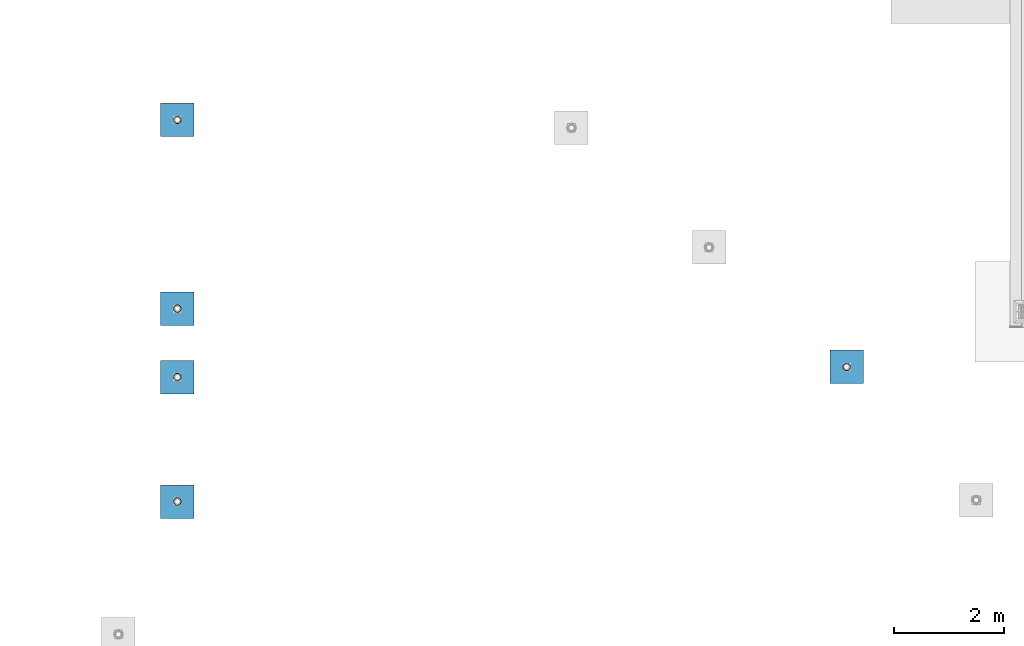
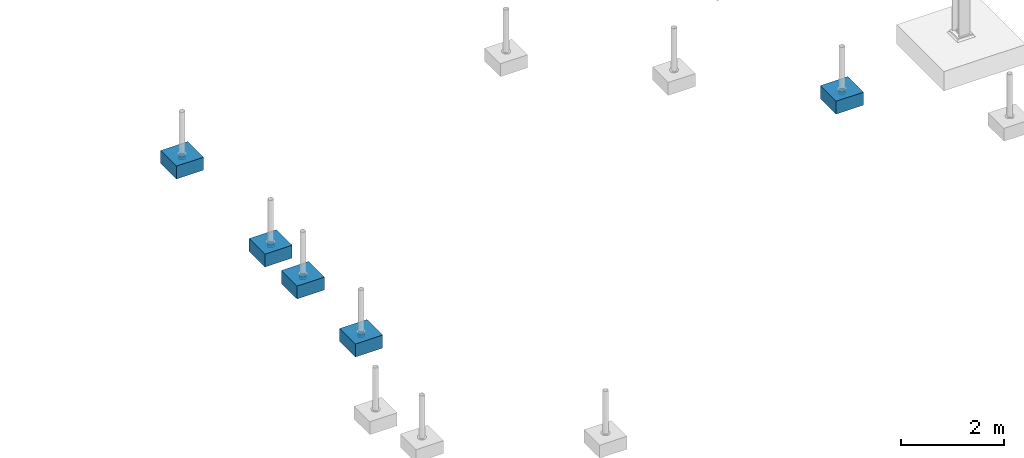
# One storey, part 1534 of 3843: 10 columns, 10 elements without a shape of their own.
"""IFC2X3 building model written with IfcOpenShell, lengths in millimetres."""

import ifcopenshell
import ifcopenshell.guid

model = None  # the IFC model being written
_history = None  # IfcOwnerHistory: only IFC2X3 demands one
_inside = {}  # id of a spatial element -> (the spatial element, [elements in it])
_under = {}  # id of a project, library or spatial element -> (it, [spatial elements below it])
_declared = {}  # id of a project -> (the project, [libraries it declares])
_typed = {}  # id of a type object -> (the type object, [elements of that type])
_made_of = {}  # id of a material, layer set ... -> (it, [elements and type objects made of it])


def new_model(schema):
    """Start an empty IFC model of exactly this schema.

    Asked for "IFC4X3", IfcOpenShell would pick the latest addendum, in which some entities
    have other attributes; the version numbers below select the first issue.
    IFC2X3 requires an IfcOwnerHistory on every rooted entity: one is made here for all.
    """
    global model, _history
    if schema == "IFC4X3":
        model = ifcopenshell.file(schema_version=(4, 3, 0, 0))
    else:
        model = ifcopenshell.file(schema=schema)
    _inside.clear()
    _under.clear()
    _declared.clear()
    _typed.clear()
    _made_of.clear()
    _history = None
    if model.schema == "IFC2X3":
        org = make("IfcOrganization", Name="unknown")
        user = make(
            "IfcPersonAndOrganization",
            ThePerson=make("IfcPerson", FamilyName="unknown"),
            TheOrganization=org,
        )
        app = make(
            "IfcApplication",
            ApplicationDeveloper=org,
            Version="unknown",
            ApplicationFullName="unknown",
            ApplicationIdentifier="unknown",
        )
        _history = make(
            "IfcOwnerHistory",
            OwningUser=user,
            OwningApplication=app,
            ChangeAction="ADDED",
            CreationDate=0,
        )
    return model


def make(cls, **values):
    """One entity of the class cls with the attributes given. An attribute that is None is left unset."""
    return model.create_entity(
        cls, **{name: value for name, value in values.items() if value is not None}
    )


def rooted(cls, **values):
    """An entity with a GlobalId (a new one), such as an element, a storey or a relation."""
    return make(cls, GlobalId=ifcopenshell.guid.new(), OwnerHistory=_history, **values)


def si_unit(unit_type, name, prefix=None):
    """IfcSIUnit, for example si_unit("LENGTHUNIT", "METRE", prefix="MILLI")."""
    return make("IfcSIUnit", UnitType=unit_type, Prefix=prefix, Name=name)


def assignment(units):
    """IfcUnitAssignment: the units of a project."""
    return None if units is None else make("IfcUnitAssignment", Units=units)


def point(xyz):
    """IfcCartesianPoint."""
    return None if xyz is None else make("IfcCartesianPoint", Coordinates=xyz)


def direction(xyz):
    """IfcDirection."""
    return None if xyz is None else make("IfcDirection", DirectionRatios=xyz)


def frame(location, z_axis=None, x_axis=None):
    """IfcAxis2Placement3D, a coordinate frame: its origin and axes. An axis left out is left unset."""
    return make(
        "IfcAxis2Placement3D",
        Location=point(location),
        Axis=direction(z_axis),
        RefDirection=direction(x_axis),
    )


def origin_with_axes():
    """The frame at (0, 0, 0) with the z axis (0, 0, 1) and the x axis (1, 0, 0) written out."""
    return frame((0.0, 0.0, 0.0), z_axis=(0.0, 0.0, 1.0), x_axis=(1.0, 0.0, 0.0))


def place(relative_to, where):
    """IfcLocalPlacement: puts the frame where relative to a parent placement (None: the world)."""
    return make(
        "IfcLocalPlacement", PlacementRelTo=relative_to, RelativePlacement=where
    )


def context(
    kind, dimensions, precision=None, world=None, true_north=None, identifier=None
):
    """IfcGeometricRepresentationContext, for example the 3D "Model" context."""
    return make(
        "IfcGeometricRepresentationContext",
        ContextIdentifier=identifier,
        ContextType=kind,
        CoordinateSpaceDimension=dimensions,
        Precision=precision,
        WorldCoordinateSystem=world,
        TrueNorth=true_north,
    )


def subcontext(parent, identifier, kind, view, scale=None):
    """IfcGeometricRepresentationSubContext, for example "Body" below "Model"."""
    return make(
        "IfcGeometricRepresentationSubContext",
        ContextIdentifier=identifier,
        ContextType=kind,
        ParentContext=parent,
        TargetScale=scale,
        TargetView=view,
    )


def project(units=None, contexts=None):
    """IfcProject with its units and contexts."""
    return rooted(
        "IfcProject",
        Name="project",
        RepresentationContexts=contexts,
        UnitsInContext=assignment(units),
    )


def spatial(cls, under=None, at=None, **own):
    """A site, building, storey or space (cls), placed at a placement, below another one or the project."""
    s = rooted(cls, ObjectPlacement=at, **own)
    if under is not None:
        _under.setdefault(under.id(), (under, []))[1].append(s)
    return s


def faces_of(points, faces, orient=None, outer=None):
    """IfcFace entities. A face is a list of loops; a loop is a list of indices into points, from 0.

    orient and outer hold one flag for each loop. By default every Orientation is true, the
    first loop of a face is its IfcFaceOuterBound and the others are IfcFaceBound.
    """
    made = []
    for i, loops in enumerate(faces):
        bounds = []
        for j, loop in enumerate(loops):
            is_outer = j == 0 if outer is None else outer[i][j]
            bounds.append(
                make(
                    "IfcFaceOuterBound" if is_outer else "IfcFaceBound",
                    Bound=make("IfcPolyLoop", Polygon=[points[k] for k in loop]),
                    Orientation=True if orient is None else orient[i][j],
                )
            )
        made.append(make("IfcFace", Bounds=bounds))
    return made


def faceted_brep(points, faces, orient=None, outer=None, voids=None):
    """IfcFacetedBrep: a solid bounded by flat faces; with voids (closed shells), ...WithVoids."""
    shared = [point(p) for p in points]
    hull = make("IfcClosedShell", CfsFaces=faces_of(shared, faces, orient, outer))
    if voids is None:
        return make("IfcFacetedBrep", Outer=hull)
    return make(
        "IfcFacetedBrepWithVoids",
        Outer=hull,
        Voids=[
            make(cls, CfsFaces=faces_of(shared, fs, o, b)) for cls, fs, o, b in voids
        ],
    )


def shape(context_of_items, identifier, shape_type, items):
    """IfcShapeRepresentation: the items that make up one representation, for example the "Body"."""
    return make(
        "IfcShapeRepresentation",
        ContextOfItems=context_of_items,
        RepresentationIdentifier=identifier,
        RepresentationType=shape_type,
        Items=items,
    )


def material(Name=None, Category=None):
    """IfcMaterial."""
    return make("IfcMaterial", Name=Name, Category=Category)


def made_of(thing, what):
    """Note that an element or type object is made of a material, layer set ...; save() writes the relation."""
    if what is not None:
        _made_of.setdefault(what.id(), (what, []))[1].append(thing)
    return thing


def type_object(cls, material=None, **own):
    """A type object (cls), such as IfcWallType, which elements share."""
    return made_of(rooted(cls, **own), material)


def element(
    cls,
    number,
    at=None,
    inside=None,
    cuts=None,
    type_object=None,
    material=None,
    context=None,
    identifier="Body",
    shape_type=None,
    held_by="IfcProductDefinitionShape",
    body=None,
    shapes=None,
    **own,
):
    """One element of the class cls, such as IfcWall. Its Tag is "e" and its number.

    at: its placement. inside: the storey or other place that contains it. cuts: it is an
    opening in that element (IfcRelVoidsElement). A single representation is given by context,
    identifier, shape_type and body (its items); several are given by shapes. held_by: the class
    of the entity that holds the representations. save() writes the other relations.
    """
    e = rooted(cls, Tag="e%d" % number, ObjectPlacement=at, **own)
    if body is not None:
        shapes = [shape(context, identifier, shape_type, body)]
    if shapes is not None:
        e.Representation = make(held_by, Representations=shapes)
    if inside is not None:
        _inside.setdefault(inside.id(), (inside, []))[1].append(e)
    if cuts is not None:
        rooted(
            "IfcRelVoidsElement", RelatingBuildingElement=cuts, RelatedOpeningElement=e
        )
    if type_object is not None:
        _typed.setdefault(type_object.id(), (type_object, []))[1].append(e)
    return made_of(e, material)


def aggregate(whole, parts):
    """IfcRelAggregates: a whole, such as a stair, and the parts it consists of."""
    return rooted("IfcRelAggregates", RelatingObject=whole, RelatedObjects=parts)


def save(model, path):
    """Write the relations noted so far, then the file.

    IfcRelAggregates (storeys below a building ...), IfcRelContainedInSpatialStructure (elements
    in a storey), IfcRelDefinesByType, IfcRelAssociatesMaterial and IfcRelDeclares: one each for
    every whole, place, type object, material and project.
    """
    for whole, parts in _under.values():
        aggregate(whole, parts)
    for where, things in _inside.values():
        rooted(
            "IfcRelContainedInSpatialStructure",
            RelatedElements=things,
            RelatingStructure=where,
        )
    for kind, things in _typed.values():
        rooted("IfcRelDefinesByType", RelatedObjects=things, RelatingType=kind)
    for what, things in _made_of.values():
        rooted("IfcRelAssociatesMaterial", RelatedObjects=things, RelatingMaterial=what)
    for by, libraries in _declared.values():
        rooted("IfcRelDeclares", RelatingContext=by, RelatedDefinitions=libraries)
    model.write(path)


model = new_model("IFC2X3")

# Units and contexts
model_context = context("Model", 3, precision=1e-05, world=origin_with_axes())
body_context = subcontext(model_context, "Body", "Model", "MODEL_VIEW")
ifc_project = project(units=[si_unit("LENGTHUNIT", "METRE", prefix="MILLI"), si_unit("AREAUNIT", "SQUARE_METRE"), si_unit("VOLUMEUNIT", "CUBIC_METRE"), si_unit("MASSUNIT", "GRAM", prefix="KILO"), si_unit("TIMEUNIT", "SECOND"), si_unit("PLANEANGLEUNIT", "RADIAN"), si_unit("SOLIDANGLEUNIT", "STERADIAN"), si_unit("THERMODYNAMICTEMPERATUREUNIT", "DEGREE_CELSIUS"), si_unit("LUMINOUSINTENSITYUNIT", "LUMEN")], contexts=[model_context])

# Site, building, storey
site_placement = place(None, origin_with_axes())
site = spatial("IfcSite", under=ifc_project, at=site_placement, CompositionType="ELEMENT")
building_placement = place(site_placement, origin_with_axes())
building = spatial("IfcBuilding", under=site, at=building_placement, Name="Undefined", CompositionType="ELEMENT")
storey_placement = place(building_placement, origin_with_axes())
storey = spatial("IfcBuildingStorey", under=building, at=storey_placement, Name="Undefined", CompositionType="ELEMENT", Elevation=0.0)

# Assembly, column
assembly_1_placement = place(storey_placement, origin_with_axes())
assembly_1 = element("IfcElementAssembly", 1, at=assembly_1_placement, inside=storey, Name="PLATE", AssemblyPlace="NOTDEFINED", PredefinedType="RIGID_FRAME")
ifc_material_1 = material()
column_type_1 = type_object("IfcColumnType", Name="PIPE5SCH40", PredefinedType="NOTDEFINED")
column_1_placement = place(assembly_1_placement, frame((-3243.064063, 88116.171877, 30378.4), z_axis=(-1.0, 0.0, 0.0), x_axis=(0.0, 0.0, 1.0)))
column_1 = element("IfcColumn", 2, at=column_1_placement, type_object=column_type_1, material=ifc_material_1, Name="PIPE_SLEEVE", ObjectType="PIPE5SCH40", context=body_context, shape_type="Brep", body=[
    faceted_brep([(0.0, -64.0587999999998, 0.0), (0.0, -60.9235391660477, 19.7952578392724), (76.2000000000007, -60.9235391660477, 19.7952578392724), (76.2000000000007, -64.0587999999998, 0.0), (0.0, -51.8246578392655, 37.6528179195593), (76.2000000000007, -51.8246578392655, 37.6528179195593), (0.0, -37.6528179195529, 51.8246578392718), (76.2000000000007, -37.6528179195529, 51.8246578392718), (0.0, -19.795257839266, 60.9235391660477), (76.2000000000007, -19.795257839266, 60.9235391660477), (0.0, 0.0, 64.0587999999989), (76.2000000000007, 0.0, 64.0587999999989), (0.0, 19.795257839266, 60.9235391660477), (76.2000000000007, 19.795257839266, 60.9235391660477), (0.0, 37.6528179195529, 51.8246578392718), (76.2000000000007, 37.6528179195529, 51.8246578392718), (0.0, 51.8246578392655, 37.6528179195593), (76.2000000000007, 51.8246578392655, 37.6528179195593), (0.0, 60.9235391660477, 19.7952578392724), (76.2000000000007, 60.9235391660477, 19.7952578392724), (0.0, 64.0587999999998, 0.0), (76.2000000000007, 64.0587999999998, 0.0), (0.0, 60.9235391660477, -19.7952578392724), (76.2000000000007, 60.9235391660477, -19.7952578392724), (0.0, 51.8246578392655, -37.6528179195593), (76.2000000000007, 51.8246578392655, -37.6528179195593), (0.0, 37.6528179195529, -51.8246578392718), (76.2000000000007, 37.6528179195529, -51.8246578392718), (0.0, 19.795257839266, -60.9235391660477), (76.2000000000007, 19.795257839266, -60.9235391660477), (0.0, 0.0, -64.0587999999989), (76.2000000000007, 0.0, -64.0587999999989), (0.0, -19.795257839266, -60.9235391660477), (76.2000000000007, -19.795257839266, -60.9235391660477), (0.0, -37.6528179195529, -51.8246578392718), (76.2000000000007, -37.6528179195529, -51.8246578392718), (0.0, -51.8246578392655, -37.6528179195593), (76.2000000000007, -51.8246578392655, -37.6528179195593), (0.0, -60.9235391660477, -19.7952578392724), (76.2000000000007, -60.9235391660477, -19.7952578392724), (0.0, -70.6120000000001, 0.0), (0.0, -67.1560027286332, -21.8203080068051), (76.2000000000007, -67.1560027286332, -21.8203080068051), (76.2000000000007, -70.6120000000001, 0.0), (0.0, -57.1263080068038, -41.5046922348702), (76.2000000000007, -57.1263080068038, -41.5046922348702), (0.0, -41.5046922348765, -57.126308006802), (76.2000000000007, -41.5046922348765, -57.126308006802), (0.0, -21.8203080068042, -67.1560027286323), (76.2000000000007, -21.8203080068042, -67.1560027286323), (0.0, 0.0, -70.6119999999937), (76.2000000000007, 0.0, -70.6119999999937), (0.0, 21.8203080068042, -67.1560027286323), (76.2000000000007, 21.8203080068042, -67.1560027286323), (0.0, 41.5046922348765, -57.126308006802), (76.2000000000007, 41.5046922348765, -57.126308006802), (0.0, 57.1263080068038, -41.5046922348702), (76.2000000000007, 57.1263080068038, -41.5046922348702), (0.0, 67.1560027286332, -21.8203080068051), (76.2000000000007, 67.1560027286332, -21.8203080068051), (0.0, 70.6120000000001, 0.0), (76.2000000000007, 70.6120000000001, 0.0), (0.0, 67.1560027286332, 21.8203080068051), (76.2000000000007, 67.1560027286332, 21.8203080068051), (0.0, 57.1263080068038, 41.5046922348702), (76.2000000000007, 57.1263080068038, 41.5046922348702), (0.0, 41.5046922348765, 57.126308006802), (76.2000000000007, 41.5046922348765, 57.126308006802), (0.0, 21.8203080068042, 67.1560027286323), (76.2000000000007, 21.8203080068042, 67.1560027286323), (0.0, 0.0, 70.6119999999937), (76.2000000000007, 0.0, 70.6119999999937), (0.0, -21.8203080068042, 67.1560027286323), (76.2000000000007, -21.8203080068042, 67.1560027286323), (0.0, -41.5046922348765, 57.126308006802), (76.2000000000007, -41.5046922348765, 57.126308006802), (0.0, -57.1263080068038, 41.5046922348702), (76.2000000000007, -57.1263080068038, 41.5046922348702), (0.0, -67.1560027286332, 21.8203080068051), (76.2000000000007, -67.1560027286332, 21.8203080068051)], [[[0, 1, 2, 3]], [[1, 4, 5, 2]], [[4, 6, 7, 5]], [[6, 8, 9, 7]], [[8, 10, 11, 9]], [[10, 12, 13, 11]], [[12, 14, 15, 13]], [[14, 16, 17, 15]], [[16, 18, 19, 17]], [[18, 20, 21, 19]], [[20, 22, 23, 21]], [[22, 24, 25, 23]], [[24, 26, 27, 25]], [[26, 28, 29, 27]], [[28, 30, 31, 29]], [[30, 32, 33, 31]], [[32, 34, 35, 33]], [[34, 36, 37, 35]], [[36, 38, 39, 37]], [[38, 0, 3, 39]], [[40, 41, 42, 43]], [[41, 44, 45, 42]], [[44, 46, 47, 45]], [[46, 48, 49, 47]], [[48, 50, 51, 49]], [[50, 52, 53, 51]], [[52, 54, 55, 53]], [[54, 56, 57, 55]], [[56, 58, 59, 57]], [[58, 60, 61, 59]], [[60, 62, 63, 61]], [[62, 64, 65, 63]], [[64, 66, 67, 65]], [[66, 68, 69, 67]], [[68, 70, 71, 69]], [[70, 72, 73, 71]], [[72, 74, 75, 73]], [[74, 76, 77, 75]], [[76, 78, 79, 77]], [[78, 40, 43, 79]], [[45, 47, 49, 51, 53, 55, 57, 59, 61, 63, 65, 67, 69, 71, 73, 75, 77, 79, 43, 42], [5, 7, 9, 11, 13, 15, 17, 19, 21, 23, 25, 27, 29, 31, 33, 35, 37, 39, 3, 2]], [[78, 76, 74, 72, 70, 68, 66, 64, 62, 60, 58, 56, 54, 52, 50, 48, 46, 44, 41, 40], [38, 36, 34, 32, 30, 28, 26, 24, 22, 20, 18, 16, 14, 12, 10, 8, 6, 4, 1, 0]]]),
])
aggregate(assembly_1, [column_1])

assembly_2_placement = place(storey_placement, origin_with_axes())
assembly_2 = element("IfcElementAssembly", 3, at=assembly_2_placement, inside=storey, Name="PLATE", AssemblyPlace="NOTDEFINED", PredefinedType="RIGID_FRAME")
column_2_placement = place(assembly_2_placement, frame((-15397.757813, 92603.240627, 30378.4), z_axis=(-1.0, 0.0, 0.0), x_axis=(0.0, 0.0, 1.0)))
column_2 = element("IfcColumn", 4, at=column_2_placement, type_object=column_type_1, material=ifc_material_1, Name="PIPE_SLEEVE", ObjectType="PIPE5SCH40", context=body_context, shape_type="Brep", body=[
    faceted_brep([(0.0, -64.0587999999998, 0.0), (0.0, -60.9235391660477, 19.7952578392724), (76.2000000000007, -60.9235391660477, 19.7952578392724), (76.2000000000007, -64.0587999999998, 0.0), (0.0, -51.8246578392655, 37.6528179195593), (76.2000000000007, -51.8246578392655, 37.6528179195593), (0.0, -37.6528179195529, 51.8246578392718), (76.2000000000007, -37.6528179195529, 51.8246578392718), (0.0, -19.795257839266, 60.9235391660477), (76.2000000000007, -19.795257839266, 60.9235391660477), (0.0, 0.0, 64.0587999999989), (76.2000000000007, 0.0, 64.0587999999989), (0.0, 19.795257839266, 60.9235391660477), (76.2000000000007, 19.795257839266, 60.9235391660477), (0.0, 37.6528179195529, 51.8246578392718), (76.2000000000007, 37.6528179195529, 51.8246578392718), (0.0, 51.8246578392655, 37.6528179195593), (76.2000000000007, 51.8246578392655, 37.6528179195593), (0.0, 60.9235391660477, 19.7952578392724), (76.2000000000007, 60.9235391660477, 19.7952578392724), (0.0, 64.0587999999998, 0.0), (76.2000000000007, 64.0587999999998, 0.0), (0.0, 60.9235391660477, -19.7952578392724), (76.2000000000007, 60.9235391660477, -19.7952578392724), (0.0, 51.8246578392655, -37.6528179195593), (76.2000000000007, 51.8246578392655, -37.6528179195593), (0.0, 37.6528179195529, -51.8246578392718), (76.2000000000007, 37.6528179195529, -51.8246578392718), (0.0, 19.795257839266, -60.9235391660477), (76.2000000000007, 19.795257839266, -60.9235391660477), (0.0, 0.0, -64.0587999999989), (76.2000000000007, 0.0, -64.0587999999989), (0.0, -19.795257839266, -60.9235391660477), (76.2000000000007, -19.795257839266, -60.9235391660477), (0.0, -37.6528179195529, -51.8246578392718), (76.2000000000007, -37.6528179195529, -51.8246578392718), (0.0, -51.8246578392655, -37.6528179195593), (76.2000000000007, -51.8246578392655, -37.6528179195593), (0.0, -60.9235391660477, -19.7952578392724), (76.2000000000007, -60.9235391660477, -19.7952578392724), (0.0, -70.6120000000001, 0.0), (0.0, -67.1560027286332, -21.8203080068051), (76.2000000000007, -67.1560027286332, -21.8203080068051), (76.2000000000007, -70.6120000000001, 0.0), (0.0, -57.1263080068038, -41.5046922348702), (76.2000000000007, -57.1263080068038, -41.5046922348702), (0.0, -41.5046922348765, -57.126308006802), (76.2000000000007, -41.5046922348765, -57.126308006802), (0.0, -21.8203080068042, -67.1560027286323), (76.2000000000007, -21.8203080068042, -67.1560027286323), (0.0, 0.0, -70.6119999999937), (76.2000000000007, 0.0, -70.6119999999937), (0.0, 21.8203080068042, -67.1560027286323), (76.2000000000007, 21.8203080068042, -67.1560027286323), (0.0, 41.5046922348765, -57.126308006802), (76.2000000000007, 41.5046922348765, -57.126308006802), (0.0, 57.1263080068038, -41.5046922348702), (76.2000000000007, 57.1263080068038, -41.5046922348702), (0.0, 67.1560027286332, -21.8203080068051), (76.2000000000007, 67.1560027286332, -21.8203080068051), (0.0, 70.6120000000001, 0.0), (76.2000000000007, 70.6120000000001, 0.0), (0.0, 67.1560027286332, 21.8203080068051), (76.2000000000007, 67.1560027286332, 21.8203080068051), (0.0, 57.1263080068038, 41.5046922348702), (76.2000000000007, 57.1263080068038, 41.5046922348702), (0.0, 41.5046922348765, 57.126308006802), (76.2000000000007, 41.5046922348765, 57.126308006802), (0.0, 21.8203080068042, 67.1560027286323), (76.2000000000007, 21.8203080068042, 67.1560027286323), (0.0, 0.0, 70.6119999999937), (76.2000000000007, 0.0, 70.6119999999937), (0.0, -21.8203080068042, 67.1560027286323), (76.2000000000007, -21.8203080068042, 67.1560027286323), (0.0, -41.5046922348765, 57.126308006802), (76.2000000000007, -41.5046922348765, 57.126308006802), (0.0, -57.1263080068038, 41.5046922348702), (76.2000000000007, -57.1263080068038, 41.5046922348702), (0.0, -67.1560027286332, 21.8203080068051), (76.2000000000007, -67.1560027286332, 21.8203080068051)], [[[0, 1, 2, 3]], [[1, 4, 5, 2]], [[4, 6, 7, 5]], [[6, 8, 9, 7]], [[8, 10, 11, 9]], [[10, 12, 13, 11]], [[12, 14, 15, 13]], [[14, 16, 17, 15]], [[16, 18, 19, 17]], [[18, 20, 21, 19]], [[20, 22, 23, 21]], [[22, 24, 25, 23]], [[24, 26, 27, 25]], [[26, 28, 29, 27]], [[28, 30, 31, 29]], [[30, 32, 33, 31]], [[32, 34, 35, 33]], [[34, 36, 37, 35]], [[36, 38, 39, 37]], [[38, 0, 3, 39]], [[40, 41, 42, 43]], [[41, 44, 45, 42]], [[44, 46, 47, 45]], [[46, 48, 49, 47]], [[48, 50, 51, 49]], [[50, 52, 53, 51]], [[52, 54, 55, 53]], [[54, 56, 57, 55]], [[56, 58, 59, 57]], [[58, 60, 61, 59]], [[60, 62, 63, 61]], [[62, 64, 65, 63]], [[64, 66, 67, 65]], [[66, 68, 69, 67]], [[68, 70, 71, 69]], [[70, 72, 73, 71]], [[72, 74, 75, 73]], [[74, 76, 77, 75]], [[76, 78, 79, 77]], [[78, 40, 43, 79]], [[45, 47, 49, 51, 53, 55, 57, 59, 61, 63, 65, 67, 69, 71, 73, 75, 77, 79, 43, 42], [5, 7, 9, 11, 13, 15, 17, 19, 21, 23, 25, 27, 29, 31, 33, 35, 37, 39, 3, 2]], [[78, 76, 74, 72, 70, 68, 66, 64, 62, 60, 58, 56, 54, 52, 50, 48, 46, 44, 41, 40], [38, 36, 34, 32, 30, 28, 26, 24, 22, 20, 18, 16, 14, 12, 10, 8, 6, 4, 1, 0]]]),
])
aggregate(assembly_2, [column_2])

assembly_3_placement = place(storey_placement, origin_with_axes())
assembly_3 = element("IfcElementAssembly", 5, at=assembly_3_placement, inside=storey, Name="PLATE", AssemblyPlace="NOTDEFINED", PredefinedType="RIGID_FRAME")
column_3_placement = place(assembly_3_placement, frame((-15397.757813, 89174.439064, 30378.4), z_axis=(-1.0, 0.0, 0.0), x_axis=(0.0, 0.0, 1.0)))
column_3 = element("IfcColumn", 6, at=column_3_placement, type_object=column_type_1, material=ifc_material_1, Name="PIPE_SLEEVE", ObjectType="PIPE5SCH40", context=body_context, shape_type="Brep", body=[
    faceted_brep([(0.0, -64.0587999999998, 0.0), (0.0, -60.9235391660477, 19.7952578392724), (76.2000000000007, -60.9235391660477, 19.7952578392724), (76.2000000000007, -64.0587999999998, 0.0), (0.0, -51.8246578392655, 37.6528179195593), (76.2000000000007, -51.8246578392655, 37.6528179195593), (0.0, -37.6528179195529, 51.8246578392718), (76.2000000000007, -37.6528179195529, 51.8246578392718), (0.0, -19.795257839266, 60.9235391660477), (76.2000000000007, -19.795257839266, 60.9235391660477), (0.0, 0.0, 64.0587999999989), (76.2000000000007, 0.0, 64.0587999999989), (0.0, 19.795257839266, 60.9235391660477), (76.2000000000007, 19.795257839266, 60.9235391660477), (0.0, 37.6528179195529, 51.8246578392718), (76.2000000000007, 37.6528179195529, 51.8246578392718), (0.0, 51.8246578392655, 37.6528179195593), (76.2000000000007, 51.8246578392655, 37.6528179195593), (0.0, 60.9235391660477, 19.7952578392724), (76.2000000000007, 60.9235391660477, 19.7952578392724), (0.0, 64.0587999999998, 0.0), (76.2000000000007, 64.0587999999998, 0.0), (0.0, 60.9235391660477, -19.7952578392724), (76.2000000000007, 60.9235391660477, -19.7952578392724), (0.0, 51.8246578392655, -37.6528179195593), (76.2000000000007, 51.8246578392655, -37.6528179195593), (0.0, 37.6528179195529, -51.8246578392718), (76.2000000000007, 37.6528179195529, -51.8246578392718), (0.0, 19.795257839266, -60.9235391660477), (76.2000000000007, 19.795257839266, -60.9235391660477), (0.0, 0.0, -64.0587999999989), (76.2000000000007, 0.0, -64.0587999999989), (0.0, -19.795257839266, -60.9235391660477), (76.2000000000007, -19.795257839266, -60.9235391660477), (0.0, -37.6528179195529, -51.8246578392718), (76.2000000000007, -37.6528179195529, -51.8246578392718), (0.0, -51.8246578392655, -37.6528179195593), (76.2000000000007, -51.8246578392655, -37.6528179195593), (0.0, -60.9235391660477, -19.7952578392724), (76.2000000000007, -60.9235391660477, -19.7952578392724), (0.0, -70.6120000000001, 0.0), (0.0, -67.1560027286332, -21.8203080068051), (76.2000000000007, -67.1560027286332, -21.8203080068051), (76.2000000000007, -70.6120000000001, 0.0), (0.0, -57.1263080068038, -41.5046922348702), (76.2000000000007, -57.1263080068038, -41.5046922348702), (0.0, -41.5046922348765, -57.126308006802), (76.2000000000007, -41.5046922348765, -57.126308006802), (0.0, -21.8203080068042, -67.1560027286323), (76.2000000000007, -21.8203080068042, -67.1560027286323), (0.0, 0.0, -70.6119999999937), (76.2000000000007, 0.0, -70.6119999999937), (0.0, 21.8203080068042, -67.1560027286323), (76.2000000000007, 21.8203080068042, -67.1560027286323), (0.0, 41.5046922348765, -57.126308006802), (76.2000000000007, 41.5046922348765, -57.126308006802), (0.0, 57.1263080068038, -41.5046922348702), (76.2000000000007, 57.1263080068038, -41.5046922348702), (0.0, 67.1560027286332, -21.8203080068051), (76.2000000000007, 67.1560027286332, -21.8203080068051), (0.0, 70.6120000000001, 0.0), (76.2000000000007, 70.6120000000001, 0.0), (0.0, 67.1560027286332, 21.8203080068051), (76.2000000000007, 67.1560027286332, 21.8203080068051), (0.0, 57.1263080068038, 41.5046922348702), (76.2000000000007, 57.1263080068038, 41.5046922348702), (0.0, 41.5046922348765, 57.126308006802), (76.2000000000007, 41.5046922348765, 57.126308006802), (0.0, 21.8203080068042, 67.1560027286323), (76.2000000000007, 21.8203080068042, 67.1560027286323), (0.0, 0.0, 70.6119999999937), (76.2000000000007, 0.0, 70.6119999999937), (0.0, -21.8203080068042, 67.1560027286323), (76.2000000000007, -21.8203080068042, 67.1560027286323), (0.0, -41.5046922348765, 57.126308006802), (76.2000000000007, -41.5046922348765, 57.126308006802), (0.0, -57.1263080068038, 41.5046922348702), (76.2000000000007, -57.1263080068038, 41.5046922348702), (0.0, -67.1560027286332, 21.8203080068051), (76.2000000000007, -67.1560027286332, 21.8203080068051)], [[[0, 1, 2, 3]], [[1, 4, 5, 2]], [[4, 6, 7, 5]], [[6, 8, 9, 7]], [[8, 10, 11, 9]], [[10, 12, 13, 11]], [[12, 14, 15, 13]], [[14, 16, 17, 15]], [[16, 18, 19, 17]], [[18, 20, 21, 19]], [[20, 22, 23, 21]], [[22, 24, 25, 23]], [[24, 26, 27, 25]], [[26, 28, 29, 27]], [[28, 30, 31, 29]], [[30, 32, 33, 31]], [[32, 34, 35, 33]], [[34, 36, 37, 35]], [[36, 38, 39, 37]], [[38, 0, 3, 39]], [[40, 41, 42, 43]], [[41, 44, 45, 42]], [[44, 46, 47, 45]], [[46, 48, 49, 47]], [[48, 50, 51, 49]], [[50, 52, 53, 51]], [[52, 54, 55, 53]], [[54, 56, 57, 55]], [[56, 58, 59, 57]], [[58, 60, 61, 59]], [[60, 62, 63, 61]], [[62, 64, 65, 63]], [[64, 66, 67, 65]], [[66, 68, 69, 67]], [[68, 70, 71, 69]], [[70, 72, 73, 71]], [[72, 74, 75, 73]], [[74, 76, 77, 75]], [[76, 78, 79, 77]], [[78, 40, 43, 79]], [[45, 47, 49, 51, 53, 55, 57, 59, 61, 63, 65, 67, 69, 71, 73, 75, 77, 79, 43, 42], [5, 7, 9, 11, 13, 15, 17, 19, 21, 23, 25, 27, 29, 31, 33, 35, 37, 39, 3, 2]], [[78, 76, 74, 72, 70, 68, 66, 64, 62, 60, 58, 56, 54, 52, 50, 48, 46, 44, 41, 40], [38, 36, 34, 32, 30, 28, 26, 24, 22, 20, 18, 16, 14, 12, 10, 8, 6, 4, 1, 0]]]),
])
aggregate(assembly_3, [column_3])

assembly_4_placement = place(storey_placement, origin_with_axes())
assembly_4 = element("IfcElementAssembly", 7, at=assembly_4_placement, inside=storey, Name="PLATE", AssemblyPlace="NOTDEFINED", PredefinedType="RIGID_FRAME")
column_4_placement = place(assembly_4_placement, frame((-15397.757813, 87930.235939, 30378.4), z_axis=(-1.0, 0.0, 0.0), x_axis=(0.0, 0.0, 1.0)))
column_4 = element("IfcColumn", 8, at=column_4_placement, type_object=column_type_1, material=ifc_material_1, Name="PIPE_SLEEVE", ObjectType="PIPE5SCH40", context=body_context, shape_type="Brep", body=[
    faceted_brep([(0.0, -64.0587999999998, 0.0), (0.0, -60.9235391660477, 19.7952578392724), (76.2000000000007, -60.9235391660477, 19.7952578392724), (76.2000000000007, -64.0587999999998, 0.0), (0.0, -51.8246578392655, 37.6528179195593), (76.2000000000007, -51.8246578392655, 37.6528179195593), (0.0, -37.6528179195529, 51.8246578392718), (76.2000000000007, -37.6528179195529, 51.8246578392718), (0.0, -19.795257839266, 60.9235391660477), (76.2000000000007, -19.795257839266, 60.9235391660477), (0.0, 0.0, 64.0587999999989), (76.2000000000007, 0.0, 64.0587999999989), (0.0, 19.795257839266, 60.9235391660477), (76.2000000000007, 19.795257839266, 60.9235391660477), (0.0, 37.6528179195529, 51.8246578392718), (76.2000000000007, 37.6528179195529, 51.8246578392718), (0.0, 51.8246578392655, 37.6528179195593), (76.2000000000007, 51.8246578392655, 37.6528179195593), (0.0, 60.9235391660477, 19.7952578392724), (76.2000000000007, 60.9235391660477, 19.7952578392724), (0.0, 64.0587999999998, 0.0), (76.2000000000007, 64.0587999999998, 0.0), (0.0, 60.9235391660477, -19.7952578392724), (76.2000000000007, 60.9235391660477, -19.7952578392724), (0.0, 51.8246578392655, -37.6528179195593), (76.2000000000007, 51.8246578392655, -37.6528179195593), (0.0, 37.6528179195529, -51.8246578392718), (76.2000000000007, 37.6528179195529, -51.8246578392718), (0.0, 19.795257839266, -60.9235391660477), (76.2000000000007, 19.795257839266, -60.9235391660477), (0.0, 0.0, -64.0587999999989), (76.2000000000007, 0.0, -64.0587999999989), (0.0, -19.795257839266, -60.9235391660477), (76.2000000000007, -19.795257839266, -60.9235391660477), (0.0, -37.6528179195529, -51.8246578392718), (76.2000000000007, -37.6528179195529, -51.8246578392718), (0.0, -51.8246578392655, -37.6528179195593), (76.2000000000007, -51.8246578392655, -37.6528179195593), (0.0, -60.9235391660477, -19.7952578392724), (76.2000000000007, -60.9235391660477, -19.7952578392724), (0.0, -70.6120000000001, 0.0), (0.0, -67.1560027286332, -21.8203080068051), (76.2000000000007, -67.1560027286332, -21.8203080068051), (76.2000000000007, -70.6120000000001, 0.0), (0.0, -57.1263080068038, -41.5046922348702), (76.2000000000007, -57.1263080068038, -41.5046922348702), (0.0, -41.5046922348765, -57.126308006802), (76.2000000000007, -41.5046922348765, -57.126308006802), (0.0, -21.8203080068042, -67.1560027286323), (76.2000000000007, -21.8203080068042, -67.1560027286323), (0.0, 0.0, -70.6119999999937), (76.2000000000007, 0.0, -70.6119999999937), (0.0, 21.8203080068042, -67.1560027286323), (76.2000000000007, 21.8203080068042, -67.1560027286323), (0.0, 41.5046922348765, -57.126308006802), (76.2000000000007, 41.5046922348765, -57.126308006802), (0.0, 57.1263080068038, -41.5046922348702), (76.2000000000007, 57.1263080068038, -41.5046922348702), (0.0, 67.1560027286332, -21.8203080068051), (76.2000000000007, 67.1560027286332, -21.8203080068051), (0.0, 70.6120000000001, 0.0), (76.2000000000007, 70.6120000000001, 0.0), (0.0, 67.1560027286332, 21.8203080068051), (76.2000000000007, 67.1560027286332, 21.8203080068051), (0.0, 57.1263080068038, 41.5046922348702), (76.2000000000007, 57.1263080068038, 41.5046922348702), (0.0, 41.5046922348765, 57.126308006802), (76.2000000000007, 41.5046922348765, 57.126308006802), (0.0, 21.8203080068042, 67.1560027286323), (76.2000000000007, 21.8203080068042, 67.1560027286323), (0.0, 0.0, 70.6119999999937), (76.2000000000007, 0.0, 70.6119999999937), (0.0, -21.8203080068042, 67.1560027286323), (76.2000000000007, -21.8203080068042, 67.1560027286323), (0.0, -41.5046922348765, 57.126308006802), (76.2000000000007, -41.5046922348765, 57.126308006802), (0.0, -57.1263080068038, 41.5046922348702), (76.2000000000007, -57.1263080068038, 41.5046922348702), (0.0, -67.1560027286332, 21.8203080068051), (76.2000000000007, -67.1560027286332, 21.8203080068051)], [[[0, 1, 2, 3]], [[1, 4, 5, 2]], [[4, 6, 7, 5]], [[6, 8, 9, 7]], [[8, 10, 11, 9]], [[10, 12, 13, 11]], [[12, 14, 15, 13]], [[14, 16, 17, 15]], [[16, 18, 19, 17]], [[18, 20, 21, 19]], [[20, 22, 23, 21]], [[22, 24, 25, 23]], [[24, 26, 27, 25]], [[26, 28, 29, 27]], [[28, 30, 31, 29]], [[30, 32, 33, 31]], [[32, 34, 35, 33]], [[34, 36, 37, 35]], [[36, 38, 39, 37]], [[38, 0, 3, 39]], [[40, 41, 42, 43]], [[41, 44, 45, 42]], [[44, 46, 47, 45]], [[46, 48, 49, 47]], [[48, 50, 51, 49]], [[50, 52, 53, 51]], [[52, 54, 55, 53]], [[54, 56, 57, 55]], [[56, 58, 59, 57]], [[58, 60, 61, 59]], [[60, 62, 63, 61]], [[62, 64, 65, 63]], [[64, 66, 67, 65]], [[66, 68, 69, 67]], [[68, 70, 71, 69]], [[70, 72, 73, 71]], [[72, 74, 75, 73]], [[74, 76, 77, 75]], [[76, 78, 79, 77]], [[78, 40, 43, 79]], [[45, 47, 49, 51, 53, 55, 57, 59, 61, 63, 65, 67, 69, 71, 73, 75, 77, 79, 43, 42], [5, 7, 9, 11, 13, 15, 17, 19, 21, 23, 25, 27, 29, 31, 33, 35, 37, 39, 3, 2]], [[78, 76, 74, 72, 70, 68, 66, 64, 62, 60, 58, 56, 54, 52, 50, 48, 46, 44, 41, 40], [38, 36, 34, 32, 30, 28, 26, 24, 22, 20, 18, 16, 14, 12, 10, 8, 6, 4, 1, 0]]]),
])
aggregate(assembly_4, [column_4])

assembly_5_placement = place(storey_placement, origin_with_axes())
assembly_5 = element("IfcElementAssembly", 9, at=assembly_5_placement, inside=storey, Name="PLATE", AssemblyPlace="NOTDEFINED", PredefinedType="RIGID_FRAME")
column_5_placement = place(assembly_5_placement, frame((-15397.757813, 85671.223439, 30378.4), z_axis=(-1.0, 0.0, 0.0), x_axis=(0.0, 0.0, 1.0)))
column_5 = element("IfcColumn", 10, at=column_5_placement, type_object=column_type_1, material=ifc_material_1, Name="PIPE_SLEEVE", ObjectType="PIPE5SCH40", context=body_context, shape_type="Brep", body=[
    faceted_brep([(0.0, -64.0587999999998, 0.0), (0.0, -60.9235391660477, 19.7952578392724), (76.2000000000007, -60.9235391660477, 19.7952578392724), (76.2000000000007, -64.0587999999998, 0.0), (0.0, -51.8246578392655, 37.6528179195593), (76.2000000000007, -51.8246578392655, 37.6528179195593), (0.0, -37.6528179195529, 51.8246578392718), (76.2000000000007, -37.6528179195529, 51.8246578392718), (0.0, -19.795257839266, 60.9235391660477), (76.2000000000007, -19.795257839266, 60.9235391660477), (0.0, 0.0, 64.0587999999989), (76.2000000000007, 0.0, 64.0587999999989), (0.0, 19.795257839266, 60.9235391660477), (76.2000000000007, 19.795257839266, 60.9235391660477), (0.0, 37.6528179195529, 51.8246578392718), (76.2000000000007, 37.6528179195529, 51.8246578392718), (0.0, 51.8246578392655, 37.6528179195593), (76.2000000000007, 51.8246578392655, 37.6528179195593), (0.0, 60.9235391660477, 19.7952578392724), (76.2000000000007, 60.9235391660477, 19.7952578392724), (0.0, 64.0587999999998, 0.0), (76.2000000000007, 64.0587999999998, 0.0), (0.0, 60.9235391660477, -19.7952578392724), (76.2000000000007, 60.9235391660477, -19.7952578392724), (0.0, 51.8246578392655, -37.6528179195593), (76.2000000000007, 51.8246578392655, -37.6528179195593), (0.0, 37.6528179195529, -51.8246578392718), (76.2000000000007, 37.6528179195529, -51.8246578392718), (0.0, 19.795257839266, -60.9235391660477), (76.2000000000007, 19.795257839266, -60.9235391660477), (0.0, 0.0, -64.0587999999989), (76.2000000000007, 0.0, -64.0587999999989), (0.0, -19.795257839266, -60.9235391660477), (76.2000000000007, -19.795257839266, -60.9235391660477), (0.0, -37.6528179195529, -51.8246578392718), (76.2000000000007, -37.6528179195529, -51.8246578392718), (0.0, -51.8246578392655, -37.6528179195593), (76.2000000000007, -51.8246578392655, -37.6528179195593), (0.0, -60.9235391660477, -19.7952578392724), (76.2000000000007, -60.9235391660477, -19.7952578392724), (0.0, -70.6120000000001, 0.0), (0.0, -67.1560027286332, -21.8203080068051), (76.2000000000007, -67.1560027286332, -21.8203080068051), (76.2000000000007, -70.6120000000001, 0.0), (0.0, -57.1263080068038, -41.5046922348702), (76.2000000000007, -57.1263080068038, -41.5046922348702), (0.0, -41.5046922348765, -57.126308006802), (76.2000000000007, -41.5046922348765, -57.126308006802), (0.0, -21.8203080068042, -67.1560027286323), (76.2000000000007, -21.8203080068042, -67.1560027286323), (0.0, 0.0, -70.6119999999937), (76.2000000000007, 0.0, -70.6119999999937), (0.0, 21.8203080068042, -67.1560027286323), (76.2000000000007, 21.8203080068042, -67.1560027286323), (0.0, 41.5046922348765, -57.126308006802), (76.2000000000007, 41.5046922348765, -57.126308006802), (0.0, 57.1263080068038, -41.5046922348702), (76.2000000000007, 57.1263080068038, -41.5046922348702), (0.0, 67.1560027286332, -21.8203080068051), (76.2000000000007, 67.1560027286332, -21.8203080068051), (0.0, 70.6120000000001, 0.0), (76.2000000000007, 70.6120000000001, 0.0), (0.0, 67.1560027286332, 21.8203080068051), (76.2000000000007, 67.1560027286332, 21.8203080068051), (0.0, 57.1263080068038, 41.5046922348702), (76.2000000000007, 57.1263080068038, 41.5046922348702), (0.0, 41.5046922348765, 57.126308006802), (76.2000000000007, 41.5046922348765, 57.126308006802), (0.0, 21.8203080068042, 67.1560027286323), (76.2000000000007, 21.8203080068042, 67.1560027286323), (0.0, 0.0, 70.6119999999937), (76.2000000000007, 0.0, 70.6119999999937), (0.0, -21.8203080068042, 67.1560027286323), (76.2000000000007, -21.8203080068042, 67.1560027286323), (0.0, -41.5046922348765, 57.126308006802), (76.2000000000007, -41.5046922348765, 57.126308006802), (0.0, -57.1263080068038, 41.5046922348702), (76.2000000000007, -57.1263080068038, 41.5046922348702), (0.0, -67.1560027286332, 21.8203080068051), (76.2000000000007, -67.1560027286332, 21.8203080068051)], [[[0, 1, 2, 3]], [[1, 4, 5, 2]], [[4, 6, 7, 5]], [[6, 8, 9, 7]], [[8, 10, 11, 9]], [[10, 12, 13, 11]], [[12, 14, 15, 13]], [[14, 16, 17, 15]], [[16, 18, 19, 17]], [[18, 20, 21, 19]], [[20, 22, 23, 21]], [[22, 24, 25, 23]], [[24, 26, 27, 25]], [[26, 28, 29, 27]], [[28, 30, 31, 29]], [[30, 32, 33, 31]], [[32, 34, 35, 33]], [[34, 36, 37, 35]], [[36, 38, 39, 37]], [[38, 0, 3, 39]], [[40, 41, 42, 43]], [[41, 44, 45, 42]], [[44, 46, 47, 45]], [[46, 48, 49, 47]], [[48, 50, 51, 49]], [[50, 52, 53, 51]], [[52, 54, 55, 53]], [[54, 56, 57, 55]], [[56, 58, 59, 57]], [[58, 60, 61, 59]], [[60, 62, 63, 61]], [[62, 64, 65, 63]], [[64, 66, 67, 65]], [[66, 68, 69, 67]], [[68, 70, 71, 69]], [[70, 72, 73, 71]], [[72, 74, 75, 73]], [[74, 76, 77, 75]], [[76, 78, 79, 77]], [[78, 40, 43, 79]], [[45, 47, 49, 51, 53, 55, 57, 59, 61, 63, 65, 67, 69, 71, 73, 75, 77, 79, 43, 42], [5, 7, 9, 11, 13, 15, 17, 19, 21, 23, 25, 27, 29, 31, 33, 35, 37, 39, 3, 2]], [[78, 76, 74, 72, 70, 68, 66, 64, 62, 60, 58, 56, 54, 52, 50, 48, 46, 44, 41, 40], [38, 36, 34, 32, 30, 28, 26, 24, 22, 20, 18, 16, 14, 12, 10, 8, 6, 4, 1, 0]]]),
])
aggregate(assembly_5, [column_5])

assembly_6_placement = place(storey_placement, origin_with_axes())
assembly_6 = element("IfcElementAssembly", 11, at=assembly_6_placement, inside=storey, Name="CONC_COL.", AssemblyPlace="NOTDEFINED", PredefinedType="REINFORCEMENT_UNIT")
ifc_material_2 = material(Name="CONCRETE/3000")
column_type_2 = type_object("IfcColumnType", PredefinedType="NOTDEFINED")
column_6_placement = place(assembly_6_placement, frame((-3243.064063, 88116.171877, 30175.2), z_axis=(-1.0, 0.0, 0.0), x_axis=(0.0, 0.0, 1.0)))
column_6 = element("IfcColumn", 12, at=column_6_placement, type_object=column_type_2, material=ifc_material_2, Name="CONC_COL.", context=body_context, shape_type="Brep", body=[
    faceted_brep([(0.0, 304.8, -304.800000000003), (0.0, 304.8, 304.800000000003), (304.799999999999, 304.8, 304.800000000003), (304.799999999999, 304.8, -304.800000000003), (0.0, -304.8, 304.800000000003), (304.799999999999, -304.8, 304.800000000003), (0.0, -304.8, -304.800000000003), (304.799999999999, -304.8, -304.800000000003)], [[[0, 1, 2, 3]], [[1, 4, 5, 2]], [[4, 6, 7, 5]], [[6, 0, 3, 7]], [[5, 7, 3, 2]], [[6, 4, 1, 0]]]),
])
aggregate(assembly_6, [column_6])

assembly_7_placement = place(storey_placement, origin_with_axes())
assembly_7 = element("IfcElementAssembly", 13, at=assembly_7_placement, inside=storey, Name="CONC_COL.", AssemblyPlace="NOTDEFINED", PredefinedType="REINFORCEMENT_UNIT")
column_7_placement = place(assembly_7_placement, frame((-15397.757813, 92603.240627, 30175.2), z_axis=(-1.0, 0.0, 0.0), x_axis=(0.0, 0.0, 1.0)))
column_7 = element("IfcColumn", 14, at=column_7_placement, type_object=column_type_2, material=ifc_material_2, Name="CONC_COL.", context=body_context, shape_type="Brep", body=[
    faceted_brep([(0.0, 304.8, -304.800000000003), (0.0, 304.8, 304.800000000003), (304.799999999999, 304.8, 304.800000000003), (304.799999999999, 304.8, -304.800000000003), (0.0, -304.8, 304.800000000003), (304.799999999999, -304.8, 304.800000000003), (0.0, -304.8, -304.800000000003), (304.799999999999, -304.8, -304.800000000003)], [[[0, 1, 2, 3]], [[1, 4, 5, 2]], [[4, 6, 7, 5]], [[6, 0, 3, 7]], [[5, 7, 3, 2]], [[6, 4, 1, 0]]]),
])
aggregate(assembly_7, [column_7])

assembly_8_placement = place(storey_placement, origin_with_axes())
assembly_8 = element("IfcElementAssembly", 15, at=assembly_8_placement, inside=storey, Name="CONC_COL.", AssemblyPlace="NOTDEFINED", PredefinedType="REINFORCEMENT_UNIT")
column_8_placement = place(assembly_8_placement, frame((-15397.757813, 89174.439064, 30175.2), z_axis=(-1.0, 0.0, 0.0), x_axis=(0.0, 0.0, 1.0)))
column_8 = element("IfcColumn", 16, at=column_8_placement, type_object=column_type_2, material=ifc_material_2, Name="CONC_COL.", context=body_context, shape_type="Brep", body=[
    faceted_brep([(0.0, 304.8, -304.800000000003), (0.0, 304.8, 304.800000000003), (304.799999999999, 304.8, 304.800000000003), (304.799999999999, 304.8, -304.800000000003), (0.0, -304.8, 304.800000000003), (304.799999999999, -304.8, 304.800000000003), (0.0, -304.8, -304.800000000003), (304.799999999999, -304.8, -304.800000000003)], [[[0, 1, 2, 3]], [[1, 4, 5, 2]], [[4, 6, 7, 5]], [[6, 0, 3, 7]], [[5, 7, 3, 2]], [[6, 4, 1, 0]]]),
])
aggregate(assembly_8, [column_8])

assembly_9_placement = place(storey_placement, origin_with_axes())
assembly_9 = element("IfcElementAssembly", 17, at=assembly_9_placement, inside=storey, Name="CONC_COL.", AssemblyPlace="NOTDEFINED", PredefinedType="REINFORCEMENT_UNIT")
column_9_placement = place(assembly_9_placement, frame((-15397.757813, 87930.235939, 30175.2), z_axis=(-1.0, 0.0, 0.0), x_axis=(0.0, 0.0, 1.0)))
column_9 = element("IfcColumn", 18, at=column_9_placement, type_object=column_type_2, material=ifc_material_2, Name="CONC_COL.", context=body_context, shape_type="Brep", body=[
    faceted_brep([(0.0, 304.8, -304.800000000003), (0.0, 304.8, 304.800000000003), (304.799999999999, 304.8, 304.800000000003), (304.799999999999, 304.8, -304.800000000003), (0.0, -304.8, 304.800000000003), (304.799999999999, -304.8, 304.800000000003), (0.0, -304.8, -304.800000000003), (304.799999999999, -304.8, -304.800000000003)], [[[0, 1, 2, 3]], [[1, 4, 5, 2]], [[4, 6, 7, 5]], [[6, 0, 3, 7]], [[5, 7, 3, 2]], [[6, 4, 1, 0]]]),
])
aggregate(assembly_9, [column_9])

assembly_10_placement = place(storey_placement, origin_with_axes())
assembly_10 = element("IfcElementAssembly", 19, at=assembly_10_placement, inside=storey, Name="CONC_COL.", AssemblyPlace="NOTDEFINED", PredefinedType="REINFORCEMENT_UNIT")
column_10_placement = place(assembly_10_placement, frame((-15397.757813, 85671.223439, 30175.2), z_axis=(-1.0, 0.0, 0.0), x_axis=(0.0, 0.0, 1.0)))
column_10 = element("IfcColumn", 20, at=column_10_placement, type_object=column_type_2, material=ifc_material_2, Name="CONC_COL.", context=body_context, shape_type="Brep", body=[
    faceted_brep([(0.0, 304.8, -304.800000000003), (0.0, 304.8, 304.800000000003), (304.799999999999, 304.8, 304.800000000003), (304.799999999999, 304.8, -304.800000000003), (0.0, -304.8, 304.800000000003), (304.799999999999, -304.8, 304.800000000003), (0.0, -304.8, -304.800000000003), (304.799999999999, -304.8, -304.800000000003)], [[[0, 1, 2, 3]], [[1, 4, 5, 2]], [[4, 6, 7, 5]], [[6, 0, 3, 7]], [[5, 7, 3, 2]], [[6, 4, 1, 0]]]),
])
aggregate(assembly_10, [column_10])

save(model, "model.ifc")
